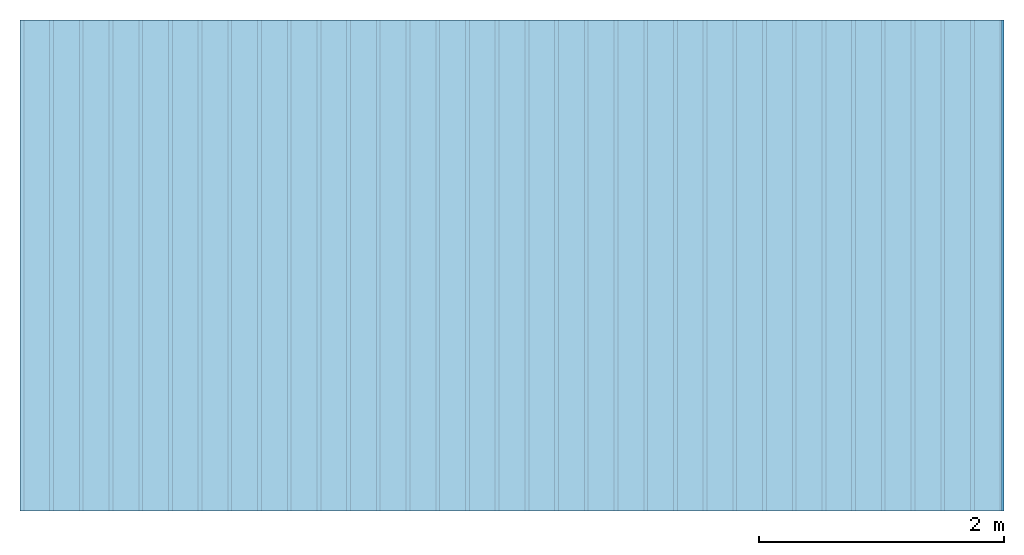
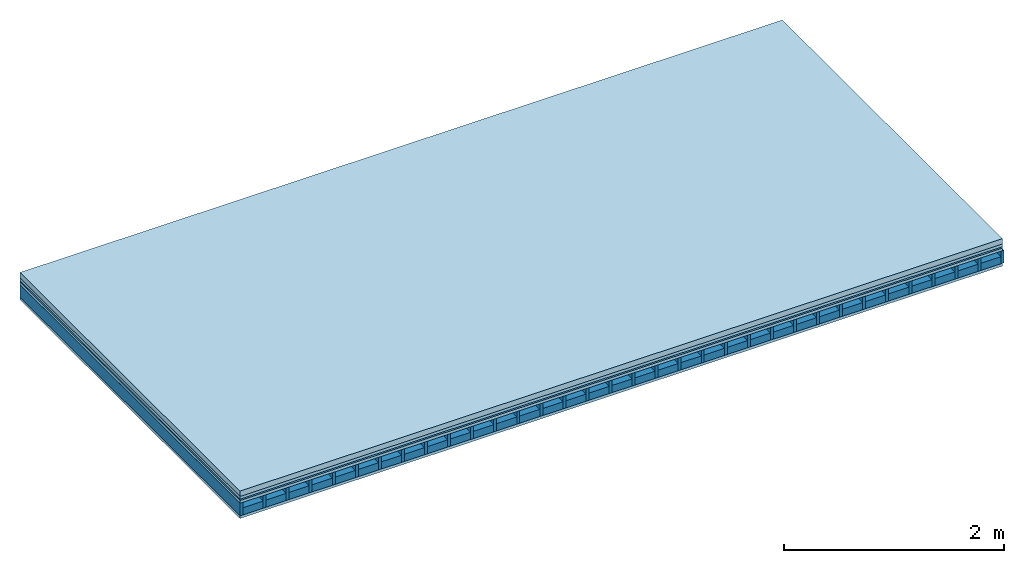
# One storey: 5 plates, 2 members, 1 element without a shape of its own.
"""IFC4 building model written with IfcOpenShell, lengths in metres."""

from ifc_helpers import new_model, si_unit, derived_unit, direction, frame, frame_2d, origin, origin_with_axes, place, context, project, spatial, rectangle, extrude, material, layer, layer_set, type_object, element, aggregate, save


model = new_model("IFC4")

# Units and contexts
plan_context = context("Plan", 3, precision=1e-05, world=origin(), true_north=direction((0.0, 1.0)))
model_context = context("Model", 3, precision=1e-05, world=origin(), true_north=direction((0.0, 1.0)))
ifc_project = project(units=[si_unit("LENGTHUNIT", "METRE"), derived_unit("SOUNDPRESSUREUNIT", [(si_unit("PRESSUREUNIT", "PASCAL", prefix="MICRO"), 0)]), si_unit("ENERGYUNIT", "JOULE", prefix="MEGA"), si_unit("MASSUNIT", "GRAM", prefix="KILO"), derived_unit("THERMALTRANSMITTANCEUNIT", [(si_unit("POWERUNIT", "WATT"), 1), (si_unit("AREAUNIT", "SQUARE_METRE"), -1), (si_unit("THERMODYNAMICTEMPERATUREUNIT", "KELVIN"), -1)]), derived_unit("AREADENSITYUNIT", [(si_unit("MASSUNIT", "GRAM", prefix="KILO"), 1), (si_unit("AREAUNIT", "SQUARE_METRE"), -1)]), derived_unit("USERDEFINED", [(si_unit("ENERGYUNIT", "JOULE", prefix="MEGA"), 1), (si_unit("AREAUNIT", "SQUARE_METRE"), -1)])], contexts=[plan_context, model_context])

# Site, building, storey
site = spatial("IfcSite", under=ifc_project)
building_placement = place(None, origin())
building = spatial("IfcBuilding", under=site, at=building_placement)
storey_placement = place(building_placement, origin())
storey = spatial("IfcBuildingStorey", under=building, at=storey_placement)

# Slab, members, plates
ifc_material_1 = material(Name="Cement screed", Category="04.006")
ifc_layer_1 = layer(ifc_material_1, 0.06, Name="On-material")
ifc_material_2 = material()
ifc_layer_2 = layer(ifc_material_2, 0.03, Name="Impact sound insulation")
ifc_material_3 = material(Name="OSB panel", Category="07.013")
ifc_layer_3 = layer(ifc_material_3, 0.015, Name="Additional insulation")
ifc_material_4 = material(Name="Element above")
ifc_layer_4 = layer(ifc_material_4, 0.0305, Name="Sub-floor")
ifc_material_5 = material(Name="Rigid")
ifc_layer_5 = layer(ifc_material_5, 0.0, Name="Bond")
ifc_layer_6 = layer(None, 0.139, Name="Supporting structure")
ifc_material_6 = material(Name="Rigid, of the art")
ifc_layer_7 = layer(ifc_material_6, 0.0, Name="Bond")
ifc_material_7 = material(Name="Element below")
ifc_layer_8 = layer(ifc_material_7, 0.0305, Name="Lower layer 1")
ifc_layer_set = layer_set([ifc_layer_1, ifc_layer_2, ifc_layer_3, ifc_layer_4, ifc_layer_5, ifc_layer_6, ifc_layer_7, ifc_layer_8])
slab_type = type_object("IfcSlabType", Name="A2278", PredefinedType="NOTDEFINED", material=ifc_layer_set)
slab_placement = place(None, frame((0.0, 0.0, 0.0), z_axis=(0.0, 0.0, -1.0), x_axis=(1.0, 0.0, 0.0)))
slab = element("IfcSlab", 1, at=slab_placement, inside=storey, type_object=slab_type, material=ifc_layer_set, Name="Slab #1")
ifc_material_8 = material(Name="Floor element EB")
member_1_placement = place(slab_placement, origin())
member_1 = element("IfcMember", 2, at=member_1_placement, material=ifc_material_8, Name="Supporting structure", context=plan_context, shape_type="SweptSolid", body=[
    extrude(rectangle(XDim=0.031, YDim=0.139, at=frame_2d((0.0155, 0.0695), x_axis=(1.0, 0.0))), frame((0.0, 4.0, 0.1355), z_axis=(0.0, -1.0, 0.0), x_axis=(1.0, 0.0, 0.0)), (0.0, 0.0, 1.0), 4.0),
    extrude(rectangle(XDim=0.031, YDim=0.139, at=frame_2d((0.0155, 0.0695), x_axis=(1.0, 0.0))), frame((0.242, 4.0, 0.1355), z_axis=(0.0, -1.0, 0.0), x_axis=(1.0, 0.0, 0.0)), (0.0, 0.0, 1.0), 4.0),
    extrude(rectangle(XDim=0.031, YDim=0.139, at=frame_2d((0.0155, 0.0695), x_axis=(1.0, 0.0))), frame((0.484, 4.0, 0.1355), z_axis=(0.0, -1.0, 0.0), x_axis=(1.0, 0.0, 0.0)), (0.0, 0.0, 1.0), 4.0),
    extrude(rectangle(XDim=0.031, YDim=0.139, at=frame_2d((0.0155, 0.0695), x_axis=(1.0, 0.0))), frame((0.726, 4.0, 0.1355), z_axis=(0.0, -1.0, 0.0), x_axis=(1.0, 0.0, 0.0)), (0.0, 0.0, 1.0), 4.0),
    extrude(rectangle(XDim=0.031, YDim=0.139, at=frame_2d((0.0155, 0.0695), x_axis=(1.0, 0.0))), frame((0.968, 4.0, 0.1355), z_axis=(0.0, -1.0, 0.0), x_axis=(1.0, 0.0, 0.0)), (0.0, 0.0, 1.0), 4.0),
    extrude(rectangle(XDim=0.031, YDim=0.139, at=frame_2d((0.0155, 0.0695), x_axis=(1.0, 0.0))), frame((1.21, 4.0, 0.1355), z_axis=(0.0, -1.0, 0.0), x_axis=(1.0, 0.0, 0.0)), (0.0, 0.0, 1.0), 4.0),
    extrude(rectangle(XDim=0.031, YDim=0.139, at=frame_2d((0.0155, 0.0695), x_axis=(1.0, 0.0))), frame((1.452, 4.0, 0.1355), z_axis=(0.0, -1.0, 0.0), x_axis=(1.0, 0.0, 0.0)), (0.0, 0.0, 1.0), 4.0),
    extrude(rectangle(XDim=0.031, YDim=0.139, at=frame_2d((0.0155, 0.0695), x_axis=(1.0, 0.0))), frame((1.694, 4.0, 0.1355), z_axis=(0.0, -1.0, 0.0), x_axis=(1.0, 0.0, 0.0)), (0.0, 0.0, 1.0), 4.0),
    extrude(rectangle(XDim=0.031, YDim=0.139, at=frame_2d((0.0155, 0.0695), x_axis=(1.0, 0.0))), frame((1.936, 4.0, 0.1355), z_axis=(0.0, -1.0, 0.0), x_axis=(1.0, 0.0, 0.0)), (0.0, 0.0, 1.0), 4.0),
    extrude(rectangle(XDim=0.031, YDim=0.139, at=frame_2d((0.0155, 0.0695), x_axis=(1.0, 0.0))), frame((2.178, 4.0, 0.1355), z_axis=(0.0, -1.0, 0.0), x_axis=(1.0, 0.0, 0.0)), (0.0, 0.0, 1.0), 4.0),
    extrude(rectangle(XDim=0.031, YDim=0.139, at=frame_2d((0.0155, 0.0695), x_axis=(1.0, 0.0))), frame((2.42, 4.0, 0.1355), z_axis=(0.0, -1.0, 0.0), x_axis=(1.0, 0.0, 0.0)), (0.0, 0.0, 1.0), 4.0),
    extrude(rectangle(XDim=0.031, YDim=0.139, at=frame_2d((0.0155, 0.0695), x_axis=(1.0, 0.0))), frame((2.662, 4.0, 0.1355), z_axis=(0.0, -1.0, 0.0), x_axis=(1.0, 0.0, 0.0)), (0.0, 0.0, 1.0), 4.0),
    extrude(rectangle(XDim=0.031, YDim=0.139, at=frame_2d((0.0155, 0.0695), x_axis=(1.0, 0.0))), frame((2.904, 4.0, 0.1355), z_axis=(0.0, -1.0, 0.0), x_axis=(1.0, 0.0, 0.0)), (0.0, 0.0, 1.0), 4.0),
    extrude(rectangle(XDim=0.031, YDim=0.139, at=frame_2d((0.0155, 0.0695), x_axis=(1.0, 0.0))), frame((3.146, 4.0, 0.1355), z_axis=(0.0, -1.0, 0.0), x_axis=(1.0, 0.0, 0.0)), (0.0, 0.0, 1.0), 4.0),
    extrude(rectangle(XDim=0.031, YDim=0.139, at=frame_2d((0.0155, 0.0695), x_axis=(1.0, 0.0))), frame((3.388, 4.0, 0.1355), z_axis=(0.0, -1.0, 0.0), x_axis=(1.0, 0.0, 0.0)), (0.0, 0.0, 1.0), 4.0),
    extrude(rectangle(XDim=0.031, YDim=0.139, at=frame_2d((0.0155, 0.0695), x_axis=(1.0, 0.0))), frame((3.63, 4.0, 0.1355), z_axis=(0.0, -1.0, 0.0), x_axis=(1.0, 0.0, 0.0)), (0.0, 0.0, 1.0), 4.0),
    extrude(rectangle(XDim=0.031, YDim=0.139, at=frame_2d((0.0155, 0.0695), x_axis=(1.0, 0.0))), frame((3.872, 4.0, 0.1355), z_axis=(0.0, -1.0, 0.0), x_axis=(1.0, 0.0, 0.0)), (0.0, 0.0, 1.0), 4.0),
    extrude(rectangle(XDim=0.031, YDim=0.139, at=frame_2d((0.0155, 0.0695), x_axis=(1.0, 0.0))), frame((4.114, 4.0, 0.1355), z_axis=(0.0, -1.0, 0.0), x_axis=(1.0, 0.0, 0.0)), (0.0, 0.0, 1.0), 4.0),
    extrude(rectangle(XDim=0.031, YDim=0.139, at=frame_2d((0.0155, 0.0695), x_axis=(1.0, 0.0))), frame((4.356, 4.0, 0.1355), z_axis=(0.0, -1.0, 0.0), x_axis=(1.0, 0.0, 0.0)), (0.0, 0.0, 1.0), 4.0),
    extrude(rectangle(XDim=0.031, YDim=0.139, at=frame_2d((0.0155, 0.0695), x_axis=(1.0, 0.0))), frame((4.598, 4.0, 0.1355), z_axis=(0.0, -1.0, 0.0), x_axis=(1.0, 0.0, 0.0)), (0.0, 0.0, 1.0), 4.0),
    extrude(rectangle(XDim=0.031, YDim=0.139, at=frame_2d((0.0155, 0.0695), x_axis=(1.0, 0.0))), frame((4.84, 4.0, 0.1355), z_axis=(0.0, -1.0, 0.0), x_axis=(1.0, 0.0, 0.0)), (0.0, 0.0, 1.0), 4.0),
    extrude(rectangle(XDim=0.031, YDim=0.139, at=frame_2d((0.0155, 0.0695), x_axis=(1.0, 0.0))), frame((5.082, 4.0, 0.1355), z_axis=(0.0, -1.0, 0.0), x_axis=(1.0, 0.0, 0.0)), (0.0, 0.0, 1.0), 4.0),
    extrude(rectangle(XDim=0.031, YDim=0.139, at=frame_2d((0.0155, 0.0695), x_axis=(1.0, 0.0))), frame((5.324, 4.0, 0.1355), z_axis=(0.0, -1.0, 0.0), x_axis=(1.0, 0.0, 0.0)), (0.0, 0.0, 1.0), 4.0),
    extrude(rectangle(XDim=0.031, YDim=0.139, at=frame_2d((0.0155, 0.0695), x_axis=(1.0, 0.0))), frame((5.566, 4.0, 0.1355), z_axis=(0.0, -1.0, 0.0), x_axis=(1.0, 0.0, 0.0)), (0.0, 0.0, 1.0), 4.0),
    extrude(rectangle(XDim=0.031, YDim=0.139, at=frame_2d((0.0155, 0.0695), x_axis=(1.0, 0.0))), frame((5.808, 4.0, 0.1355), z_axis=(0.0, -1.0, 0.0), x_axis=(1.0, 0.0, 0.0)), (0.0, 0.0, 1.0), 4.0),
    extrude(rectangle(XDim=0.031, YDim=0.139, at=frame_2d((0.0155, 0.0695), x_axis=(1.0, 0.0))), frame((6.05, 4.0, 0.1355), z_axis=(0.0, -1.0, 0.0), x_axis=(1.0, 0.0, 0.0)), (0.0, 0.0, 1.0), 4.0),
    extrude(rectangle(XDim=0.031, YDim=0.139, at=frame_2d((0.0155, 0.0695), x_axis=(1.0, 0.0))), frame((6.292, 4.0, 0.1355), z_axis=(0.0, -1.0, 0.0), x_axis=(1.0, 0.0, 0.0)), (0.0, 0.0, 1.0), 4.0),
    extrude(rectangle(XDim=0.031, YDim=0.139, at=frame_2d((0.0155, 0.0695), x_axis=(1.0, 0.0))), frame((6.534, 4.0, 0.1355), z_axis=(0.0, -1.0, 0.0), x_axis=(1.0, 0.0, 0.0)), (0.0, 0.0, 1.0), 4.0),
    extrude(rectangle(XDim=0.031, YDim=0.139, at=frame_2d((0.0155, 0.0695), x_axis=(1.0, 0.0))), frame((6.776, 4.0, 0.1355), z_axis=(0.0, -1.0, 0.0), x_axis=(1.0, 0.0, 0.0)), (0.0, 0.0, 1.0), 4.0),
    extrude(rectangle(XDim=0.031, YDim=0.139, at=frame_2d((0.0155, 0.0695), x_axis=(1.0, 0.0))), frame((7.018, 4.0, 0.1355), z_axis=(0.0, -1.0, 0.0), x_axis=(1.0, 0.0, 0.0)), (0.0, 0.0, 1.0), 4.0),
    extrude(rectangle(XDim=0.031, YDim=0.139, at=frame_2d((0.0155, 0.0695), x_axis=(1.0, 0.0))), frame((7.26, 4.0, 0.1355), z_axis=(0.0, -1.0, 0.0), x_axis=(1.0, 0.0, 0.0)), (0.0, 0.0, 1.0), 4.0),
    extrude(rectangle(XDim=0.031, YDim=0.139, at=frame_2d((0.0155, 0.0695), x_axis=(1.0, 0.0))), frame((7.502, 4.0, 0.1355), z_axis=(0.0, -1.0, 0.0), x_axis=(1.0, 0.0, 0.0)), (0.0, 0.0, 1.0), 4.0),
    extrude(rectangle(XDim=0.031, YDim=0.139, at=frame_2d((0.0155, 0.0695), x_axis=(1.0, 0.0))), frame((7.744, 4.0, 0.1355), z_axis=(0.0, -1.0, 0.0), x_axis=(1.0, 0.0, 0.0)), (0.0, 0.0, 1.0), 4.0),
    extrude(rectangle(XDim=0.031, YDim=0.139, at=frame_2d((0.0155, 0.0695), x_axis=(1.0, 0.0))), frame((7.986, 4.0, 0.1355), z_axis=(0.0, -1.0, 0.0), x_axis=(1.0, 0.0, 0.0)), (0.0, 0.0, 1.0), 4.0),
])
ifc_material_9 = material(Name="CCN 2-3mm")
member_2_placement = place(slab_placement, origin())
member_2 = element("IfcMember", 3, at=member_2_placement, material=ifc_material_9, Name="in supporting structure", context=plan_context, shape_type="SweptSolid", body=[
    extrude(rectangle(XDim=0.211, YDim=0.0793, at=frame_2d((0.1055, 0.03965), x_axis=(1.0, 0.0))), frame((0.031, 4.0, 0.1952), z_axis=(0.0, -1.0, 0.0), x_axis=(1.0, 0.0, 0.0)), (0.0, 0.0, 1.0), 4.0),
    extrude(rectangle(XDim=0.211, YDim=0.0793, at=frame_2d((0.1055, 0.03965), x_axis=(1.0, 0.0))), frame((0.273, 4.0, 0.1952), z_axis=(0.0, -1.0, 0.0), x_axis=(1.0, 0.0, 0.0)), (0.0, 0.0, 1.0), 4.0),
    extrude(rectangle(XDim=0.211, YDim=0.0793, at=frame_2d((0.1055, 0.03965), x_axis=(1.0, 0.0))), frame((0.515, 4.0, 0.1952), z_axis=(0.0, -1.0, 0.0), x_axis=(1.0, 0.0, 0.0)), (0.0, 0.0, 1.0), 4.0),
    extrude(rectangle(XDim=0.211, YDim=0.0793, at=frame_2d((0.1055, 0.03965), x_axis=(1.0, 0.0))), frame((0.757, 4.0, 0.1952), z_axis=(0.0, -1.0, 0.0), x_axis=(1.0, 0.0, 0.0)), (0.0, 0.0, 1.0), 4.0),
    extrude(rectangle(XDim=0.211, YDim=0.0793, at=frame_2d((0.1055, 0.03965), x_axis=(1.0, 0.0))), frame((0.999, 4.0, 0.1952), z_axis=(0.0, -1.0, 0.0), x_axis=(1.0, 0.0, 0.0)), (0.0, 0.0, 1.0), 4.0),
    extrude(rectangle(XDim=0.211, YDim=0.0793, at=frame_2d((0.1055, 0.03965), x_axis=(1.0, 0.0))), frame((1.241, 4.0, 0.1952), z_axis=(0.0, -1.0, 0.0), x_axis=(1.0, 0.0, 0.0)), (0.0, 0.0, 1.0), 4.0),
    extrude(rectangle(XDim=0.211, YDim=0.0793, at=frame_2d((0.1055, 0.03965), x_axis=(1.0, 0.0))), frame((1.483, 4.0, 0.1952), z_axis=(0.0, -1.0, 0.0), x_axis=(1.0, 0.0, 0.0)), (0.0, 0.0, 1.0), 4.0),
    extrude(rectangle(XDim=0.211, YDim=0.0793, at=frame_2d((0.1055, 0.03965), x_axis=(1.0, 0.0))), frame((1.725, 4.0, 0.1952), z_axis=(0.0, -1.0, 0.0), x_axis=(1.0, 0.0, 0.0)), (0.0, 0.0, 1.0), 4.0),
    extrude(rectangle(XDim=0.211, YDim=0.0793, at=frame_2d((0.1055, 0.03965), x_axis=(1.0, 0.0))), frame((1.967, 4.0, 0.1952), z_axis=(0.0, -1.0, 0.0), x_axis=(1.0, 0.0, 0.0)), (0.0, 0.0, 1.0), 4.0),
    extrude(rectangle(XDim=0.211, YDim=0.0793, at=frame_2d((0.1055, 0.03965), x_axis=(1.0, 0.0))), frame((2.209, 4.0, 0.1952), z_axis=(0.0, -1.0, 0.0), x_axis=(1.0, 0.0, 0.0)), (0.0, 0.0, 1.0), 4.0),
    extrude(rectangle(XDim=0.211, YDim=0.0793, at=frame_2d((0.1055, 0.03965), x_axis=(1.0, 0.0))), frame((2.451, 4.0, 0.1952), z_axis=(0.0, -1.0, 0.0), x_axis=(1.0, 0.0, 0.0)), (0.0, 0.0, 1.0), 4.0),
    extrude(rectangle(XDim=0.211, YDim=0.0793, at=frame_2d((0.1055, 0.03965), x_axis=(1.0, 0.0))), frame((2.693, 4.0, 0.1952), z_axis=(0.0, -1.0, 0.0), x_axis=(1.0, 0.0, 0.0)), (0.0, 0.0, 1.0), 4.0),
    extrude(rectangle(XDim=0.211, YDim=0.0793, at=frame_2d((0.1055, 0.03965), x_axis=(1.0, 0.0))), frame((2.935, 4.0, 0.1952), z_axis=(0.0, -1.0, 0.0), x_axis=(1.0, 0.0, 0.0)), (0.0, 0.0, 1.0), 4.0),
    extrude(rectangle(XDim=0.211, YDim=0.0793, at=frame_2d((0.1055, 0.03965), x_axis=(1.0, 0.0))), frame((3.177, 4.0, 0.1952), z_axis=(0.0, -1.0, 0.0), x_axis=(1.0, 0.0, 0.0)), (0.0, 0.0, 1.0), 4.0),
    extrude(rectangle(XDim=0.211, YDim=0.0793, at=frame_2d((0.1055, 0.03965), x_axis=(1.0, 0.0))), frame((3.419, 4.0, 0.1952), z_axis=(0.0, -1.0, 0.0), x_axis=(1.0, 0.0, 0.0)), (0.0, 0.0, 1.0), 4.0),
    extrude(rectangle(XDim=0.211, YDim=0.0793, at=frame_2d((0.1055, 0.03965), x_axis=(1.0, 0.0))), frame((3.661, 4.0, 0.1952), z_axis=(0.0, -1.0, 0.0), x_axis=(1.0, 0.0, 0.0)), (0.0, 0.0, 1.0), 4.0),
    extrude(rectangle(XDim=0.211, YDim=0.0793, at=frame_2d((0.1055, 0.03965), x_axis=(1.0, 0.0))), frame((3.903, 4.0, 0.1952), z_axis=(0.0, -1.0, 0.0), x_axis=(1.0, 0.0, 0.0)), (0.0, 0.0, 1.0), 4.0),
    extrude(rectangle(XDim=0.211, YDim=0.0793, at=frame_2d((0.1055, 0.03965), x_axis=(1.0, 0.0))), frame((4.145, 4.0, 0.1952), z_axis=(0.0, -1.0, 0.0), x_axis=(1.0, 0.0, 0.0)), (0.0, 0.0, 1.0), 4.0),
    extrude(rectangle(XDim=0.211, YDim=0.0793, at=frame_2d((0.1055, 0.03965), x_axis=(1.0, 0.0))), frame((4.387, 4.0, 0.1952), z_axis=(0.0, -1.0, 0.0), x_axis=(1.0, 0.0, 0.0)), (0.0, 0.0, 1.0), 4.0),
    extrude(rectangle(XDim=0.211, YDim=0.0793, at=frame_2d((0.1055, 0.03965), x_axis=(1.0, 0.0))), frame((4.629, 4.0, 0.1952), z_axis=(0.0, -1.0, 0.0), x_axis=(1.0, 0.0, 0.0)), (0.0, 0.0, 1.0), 4.0),
    extrude(rectangle(XDim=0.211, YDim=0.0793, at=frame_2d((0.1055, 0.03965), x_axis=(1.0, 0.0))), frame((4.871, 4.0, 0.1952), z_axis=(0.0, -1.0, 0.0), x_axis=(1.0, 0.0, 0.0)), (0.0, 0.0, 1.0), 4.0),
    extrude(rectangle(XDim=0.211, YDim=0.0793, at=frame_2d((0.1055, 0.03965), x_axis=(1.0, 0.0))), frame((5.113, 4.0, 0.1952), z_axis=(0.0, -1.0, 0.0), x_axis=(1.0, 0.0, 0.0)), (0.0, 0.0, 1.0), 4.0),
    extrude(rectangle(XDim=0.211, YDim=0.0793, at=frame_2d((0.1055, 0.03965), x_axis=(1.0, 0.0))), frame((5.355, 4.0, 0.1952), z_axis=(0.0, -1.0, 0.0), x_axis=(1.0, 0.0, 0.0)), (0.0, 0.0, 1.0), 4.0),
    extrude(rectangle(XDim=0.211, YDim=0.0793, at=frame_2d((0.1055, 0.03965), x_axis=(1.0, 0.0))), frame((5.597, 4.0, 0.1952), z_axis=(0.0, -1.0, 0.0), x_axis=(1.0, 0.0, 0.0)), (0.0, 0.0, 1.0), 4.0),
    extrude(rectangle(XDim=0.211, YDim=0.0793, at=frame_2d((0.1055, 0.03965), x_axis=(1.0, 0.0))), frame((5.839, 4.0, 0.1952), z_axis=(0.0, -1.0, 0.0), x_axis=(1.0, 0.0, 0.0)), (0.0, 0.0, 1.0), 4.0),
    extrude(rectangle(XDim=0.211, YDim=0.0793, at=frame_2d((0.1055, 0.03965), x_axis=(1.0, 0.0))), frame((6.081, 4.0, 0.1952), z_axis=(0.0, -1.0, 0.0), x_axis=(1.0, 0.0, 0.0)), (0.0, 0.0, 1.0), 4.0),
    extrude(rectangle(XDim=0.211, YDim=0.0793, at=frame_2d((0.1055, 0.03965), x_axis=(1.0, 0.0))), frame((6.323, 4.0, 0.1952), z_axis=(0.0, -1.0, 0.0), x_axis=(1.0, 0.0, 0.0)), (0.0, 0.0, 1.0), 4.0),
    extrude(rectangle(XDim=0.211, YDim=0.0793, at=frame_2d((0.1055, 0.03965), x_axis=(1.0, 0.0))), frame((6.565, 4.0, 0.1952), z_axis=(0.0, -1.0, 0.0), x_axis=(1.0, 0.0, 0.0)), (0.0, 0.0, 1.0), 4.0),
    extrude(rectangle(XDim=0.211, YDim=0.0793, at=frame_2d((0.1055, 0.03965), x_axis=(1.0, 0.0))), frame((6.807, 4.0, 0.1952), z_axis=(0.0, -1.0, 0.0), x_axis=(1.0, 0.0, 0.0)), (0.0, 0.0, 1.0), 4.0),
    extrude(rectangle(XDim=0.211, YDim=0.0793, at=frame_2d((0.1055, 0.03965), x_axis=(1.0, 0.0))), frame((7.049, 4.0, 0.1952), z_axis=(0.0, -1.0, 0.0), x_axis=(1.0, 0.0, 0.0)), (0.0, 0.0, 1.0), 4.0),
    extrude(rectangle(XDim=0.211, YDim=0.0793, at=frame_2d((0.1055, 0.03965), x_axis=(1.0, 0.0))), frame((7.291, 4.0, 0.1952), z_axis=(0.0, -1.0, 0.0), x_axis=(1.0, 0.0, 0.0)), (0.0, 0.0, 1.0), 4.0),
    extrude(rectangle(XDim=0.211, YDim=0.0793, at=frame_2d((0.1055, 0.03965), x_axis=(1.0, 0.0))), frame((7.533, 4.0, 0.1952), z_axis=(0.0, -1.0, 0.0), x_axis=(1.0, 0.0, 0.0)), (0.0, 0.0, 1.0), 4.0),
    extrude(rectangle(XDim=0.211, YDim=0.0793, at=frame_2d((0.1055, 0.03965), x_axis=(1.0, 0.0))), frame((7.775, 4.0, 0.1952), z_axis=(0.0, -1.0, 0.0), x_axis=(1.0, 0.0, 0.0)), (0.0, 0.0, 1.0), 4.0),
])
plate_1_placement = place(slab_placement, origin())
plate_1 = element("IfcPlate", 4, at=plate_1_placement, material=ifc_material_1, Name="On-material", context=plan_context, shape_type="SweptSolid", body=[
    extrude(rectangle(XDim=8.0, YDim=4.0, at=frame_2d((4.0, 2.0), x_axis=(1.0, 0.0))), origin_with_axes(), (0.0, 0.0, 1.0), 0.06),
])
plate_2_placement = place(slab_placement, origin())
plate_2 = element("IfcPlate", 5, at=plate_2_placement, material=ifc_material_2, Name="Impact sound insulation", context=plan_context, shape_type="SweptSolid", body=[
    extrude(rectangle(XDim=8.0, YDim=4.0, at=frame_2d((4.0, 2.0), x_axis=(1.0, 0.0))), frame((0.0, 0.0, 0.06), z_axis=(0.0, 0.0, 1.0), x_axis=(1.0, 0.0, 0.0)), (0.0, 0.0, 1.0), 0.03),
])
plate_3_placement = place(slab_placement, origin())
plate_3 = element("IfcPlate", 6, at=plate_3_placement, material=ifc_material_3, Name="Additional insulation", context=plan_context, shape_type="SweptSolid", body=[
    extrude(rectangle(XDim=8.0, YDim=4.0, at=frame_2d((4.0, 2.0), x_axis=(1.0, 0.0))), frame((0.0, 0.0, 0.09), z_axis=(0.0, 0.0, 1.0), x_axis=(1.0, 0.0, 0.0)), (0.0, 0.0, 1.0), 0.015),
])
plate_4_placement = place(slab_placement, origin())
plate_4 = element("IfcPlate", 7, at=plate_4_placement, material=ifc_material_4, Name="Sub-floor", context=plan_context, shape_type="SweptSolid", body=[
    extrude(rectangle(XDim=8.0, YDim=4.0, at=frame_2d((4.0, 2.0), x_axis=(1.0, 0.0))), frame((0.0, 0.0, 0.105), z_axis=(0.0, 0.0, 1.0), x_axis=(1.0, 0.0, 0.0)), (0.0, 0.0, 1.0), 0.0305),
])
plate_5_placement = place(slab_placement, origin())
plate_5 = element("IfcPlate", 8, at=plate_5_placement, material=ifc_material_7, Name="Lower layer 1", context=plan_context, shape_type="SweptSolid", body=[
    extrude(rectangle(XDim=8.0, YDim=4.0, at=frame_2d((4.0, 2.0), x_axis=(1.0, 0.0))), frame((0.0, 0.0, 0.2745), z_axis=(0.0, 0.0, 1.0), x_axis=(1.0, 0.0, 0.0)), (0.0, 0.0, 1.0), 0.0305),
])
aggregate(slab, [plate_1, plate_2, plate_3, plate_4, member_1, member_2, plate_5])

save(model, "model.ifc")
